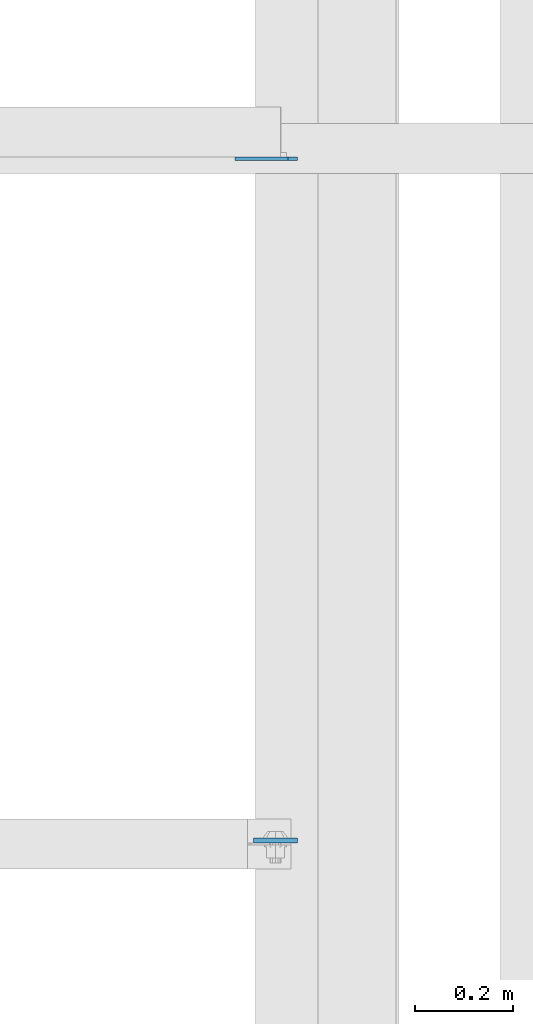
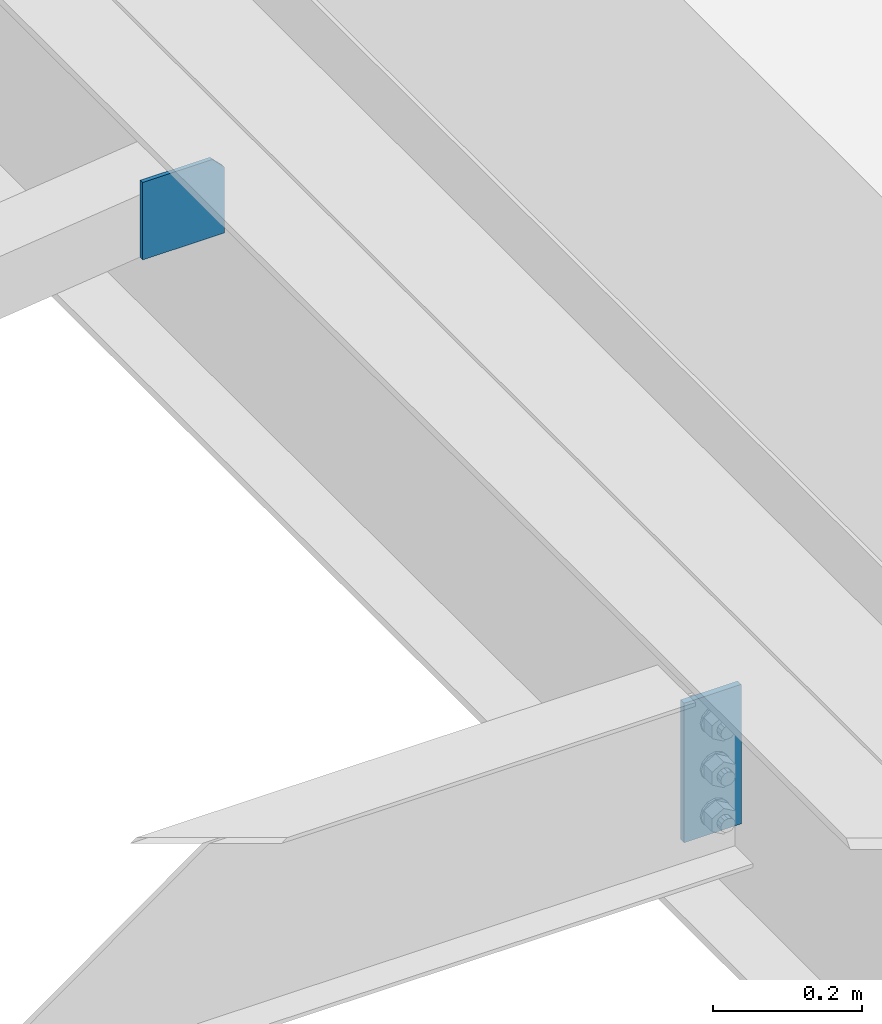
# One storey, part 3259 of 3843: 2 plates, 1 element without a shape of its own.
"""IFC2X3 building model written with IfcOpenShell, lengths in millimetres."""

import ifcopenshell
import ifcopenshell.guid

model = None  # the IFC model being written
_history = None  # IfcOwnerHistory: only IFC2X3 demands one
_inside = {}  # id of a spatial element -> (the spatial element, [elements in it])
_under = {}  # id of a project, library or spatial element -> (it, [spatial elements below it])
_declared = {}  # id of a project -> (the project, [libraries it declares])
_typed = {}  # id of a type object -> (the type object, [elements of that type])
_made_of = {}  # id of a material, layer set ... -> (it, [elements and type objects made of it])


def new_model(schema):
    """Start an empty IFC model of exactly this schema.

    Asked for "IFC4X3", IfcOpenShell would pick the latest addendum, in which some entities
    have other attributes; the version numbers below select the first issue.
    IFC2X3 requires an IfcOwnerHistory on every rooted entity: one is made here for all.
    """
    global model, _history
    if schema == "IFC4X3":
        model = ifcopenshell.file(schema_version=(4, 3, 0, 0))
    else:
        model = ifcopenshell.file(schema=schema)
    _inside.clear()
    _under.clear()
    _declared.clear()
    _typed.clear()
    _made_of.clear()
    _history = None
    if model.schema == "IFC2X3":
        org = make("IfcOrganization", Name="unknown")
        user = make(
            "IfcPersonAndOrganization",
            ThePerson=make("IfcPerson", FamilyName="unknown"),
            TheOrganization=org,
        )
        app = make(
            "IfcApplication",
            ApplicationDeveloper=org,
            Version="unknown",
            ApplicationFullName="unknown",
            ApplicationIdentifier="unknown",
        )
        _history = make(
            "IfcOwnerHistory",
            OwningUser=user,
            OwningApplication=app,
            ChangeAction="ADDED",
            CreationDate=0,
        )
    return model


def make(cls, **values):
    """One entity of the class cls with the attributes given. An attribute that is None is left unset."""
    return model.create_entity(
        cls, **{name: value for name, value in values.items() if value is not None}
    )


def rooted(cls, **values):
    """An entity with a GlobalId (a new one), such as an element, a storey or a relation."""
    return make(cls, GlobalId=ifcopenshell.guid.new(), OwnerHistory=_history, **values)


def si_unit(unit_type, name, prefix=None):
    """IfcSIUnit, for example si_unit("LENGTHUNIT", "METRE", prefix="MILLI")."""
    return make("IfcSIUnit", UnitType=unit_type, Prefix=prefix, Name=name)


def assignment(units):
    """IfcUnitAssignment: the units of a project."""
    return None if units is None else make("IfcUnitAssignment", Units=units)


def point(xyz):
    """IfcCartesianPoint."""
    return None if xyz is None else make("IfcCartesianPoint", Coordinates=xyz)


def direction(xyz):
    """IfcDirection."""
    return None if xyz is None else make("IfcDirection", DirectionRatios=xyz)


def frame(location, z_axis=None, x_axis=None):
    """IfcAxis2Placement3D, a coordinate frame: its origin and axes. An axis left out is left unset."""
    return make(
        "IfcAxis2Placement3D",
        Location=point(location),
        Axis=direction(z_axis),
        RefDirection=direction(x_axis),
    )


def origin_with_axes():
    """The frame at (0, 0, 0) with the z axis (0, 0, 1) and the x axis (1, 0, 0) written out."""
    return frame((0.0, 0.0, 0.0), z_axis=(0.0, 0.0, 1.0), x_axis=(1.0, 0.0, 0.0))


def place(relative_to, where):
    """IfcLocalPlacement: puts the frame where relative to a parent placement (None: the world)."""
    return make(
        "IfcLocalPlacement", PlacementRelTo=relative_to, RelativePlacement=where
    )


def context(
    kind, dimensions, precision=None, world=None, true_north=None, identifier=None
):
    """IfcGeometricRepresentationContext, for example the 3D "Model" context."""
    return make(
        "IfcGeometricRepresentationContext",
        ContextIdentifier=identifier,
        ContextType=kind,
        CoordinateSpaceDimension=dimensions,
        Precision=precision,
        WorldCoordinateSystem=world,
        TrueNorth=true_north,
    )


def subcontext(parent, identifier, kind, view, scale=None):
    """IfcGeometricRepresentationSubContext, for example "Body" below "Model"."""
    return make(
        "IfcGeometricRepresentationSubContext",
        ContextIdentifier=identifier,
        ContextType=kind,
        ParentContext=parent,
        TargetScale=scale,
        TargetView=view,
    )


def project(units=None, contexts=None):
    """IfcProject with its units and contexts."""
    return rooted(
        "IfcProject",
        Name="project",
        RepresentationContexts=contexts,
        UnitsInContext=assignment(units),
    )


def spatial(cls, under=None, at=None, **own):
    """A site, building, storey or space (cls), placed at a placement, below another one or the project."""
    s = rooted(cls, ObjectPlacement=at, **own)
    if under is not None:
        _under.setdefault(under.id(), (under, []))[1].append(s)
    return s


def faces_of(points, faces, orient=None, outer=None):
    """IfcFace entities. A face is a list of loops; a loop is a list of indices into points, from 0.

    orient and outer hold one flag for each loop. By default every Orientation is true, the
    first loop of a face is its IfcFaceOuterBound and the others are IfcFaceBound.
    """
    made = []
    for i, loops in enumerate(faces):
        bounds = []
        for j, loop in enumerate(loops):
            is_outer = j == 0 if outer is None else outer[i][j]
            bounds.append(
                make(
                    "IfcFaceOuterBound" if is_outer else "IfcFaceBound",
                    Bound=make("IfcPolyLoop", Polygon=[points[k] for k in loop]),
                    Orientation=True if orient is None else orient[i][j],
                )
            )
        made.append(make("IfcFace", Bounds=bounds))
    return made


def faceted_brep(points, faces, orient=None, outer=None, voids=None):
    """IfcFacetedBrep: a solid bounded by flat faces; with voids (closed shells), ...WithVoids."""
    shared = [point(p) for p in points]
    hull = make("IfcClosedShell", CfsFaces=faces_of(shared, faces, orient, outer))
    if voids is None:
        return make("IfcFacetedBrep", Outer=hull)
    return make(
        "IfcFacetedBrepWithVoids",
        Outer=hull,
        Voids=[
            make(cls, CfsFaces=faces_of(shared, fs, o, b)) for cls, fs, o, b in voids
        ],
    )


def shape(context_of_items, identifier, shape_type, items):
    """IfcShapeRepresentation: the items that make up one representation, for example the "Body"."""
    return make(
        "IfcShapeRepresentation",
        ContextOfItems=context_of_items,
        RepresentationIdentifier=identifier,
        RepresentationType=shape_type,
        Items=items,
    )


def material(Name=None, Category=None):
    """IfcMaterial."""
    return make("IfcMaterial", Name=Name, Category=Category)


def made_of(thing, what):
    """Note that an element or type object is made of a material, layer set ...; save() writes the relation."""
    if what is not None:
        _made_of.setdefault(what.id(), (what, []))[1].append(thing)
    return thing


def type_object(cls, material=None, **own):
    """A type object (cls), such as IfcWallType, which elements share."""
    return made_of(rooted(cls, **own), material)


def element(
    cls,
    number,
    at=None,
    inside=None,
    cuts=None,
    type_object=None,
    material=None,
    context=None,
    identifier="Body",
    shape_type=None,
    held_by="IfcProductDefinitionShape",
    body=None,
    shapes=None,
    **own,
):
    """One element of the class cls, such as IfcWall. Its Tag is "e" and its number.

    at: its placement. inside: the storey or other place that contains it. cuts: it is an
    opening in that element (IfcRelVoidsElement). A single representation is given by context,
    identifier, shape_type and body (its items); several are given by shapes. held_by: the class
    of the entity that holds the representations. save() writes the other relations.
    """
    e = rooted(cls, Tag="e%d" % number, ObjectPlacement=at, **own)
    if body is not None:
        shapes = [shape(context, identifier, shape_type, body)]
    if shapes is not None:
        e.Representation = make(held_by, Representations=shapes)
    if inside is not None:
        _inside.setdefault(inside.id(), (inside, []))[1].append(e)
    if cuts is not None:
        rooted(
            "IfcRelVoidsElement", RelatingBuildingElement=cuts, RelatedOpeningElement=e
        )
    if type_object is not None:
        _typed.setdefault(type_object.id(), (type_object, []))[1].append(e)
    return made_of(e, material)


def aggregate(whole, parts):
    """IfcRelAggregates: a whole, such as a stair, and the parts it consists of."""
    return rooted("IfcRelAggregates", RelatingObject=whole, RelatedObjects=parts)


def save(model, path):
    """Write the relations noted so far, then the file.

    IfcRelAggregates (storeys below a building ...), IfcRelContainedInSpatialStructure (elements
    in a storey), IfcRelDefinesByType, IfcRelAssociatesMaterial and IfcRelDeclares: one each for
    every whole, place, type object, material and project.
    """
    for whole, parts in _under.values():
        aggregate(whole, parts)
    for where, things in _inside.values():
        rooted(
            "IfcRelContainedInSpatialStructure",
            RelatedElements=things,
            RelatingStructure=where,
        )
    for kind, things in _typed.values():
        rooted("IfcRelDefinesByType", RelatedObjects=things, RelatingType=kind)
    for what, things in _made_of.values():
        rooted("IfcRelAssociatesMaterial", RelatedObjects=things, RelatingMaterial=what)
    for by, libraries in _declared.values():
        rooted("IfcRelDeclares", RelatingContext=by, RelatedDefinitions=libraries)
    model.write(path)


model = new_model("IFC2X3")

# Units and contexts
model_context = context("Model", 3, precision=1e-05, world=origin_with_axes())
body_context = subcontext(model_context, "Body", "Model", "MODEL_VIEW")
ifc_project = project(units=[si_unit("LENGTHUNIT", "METRE", prefix="MILLI"), si_unit("AREAUNIT", "SQUARE_METRE"), si_unit("VOLUMEUNIT", "CUBIC_METRE"), si_unit("MASSUNIT", "GRAM", prefix="KILO"), si_unit("TIMEUNIT", "SECOND"), si_unit("PLANEANGLEUNIT", "RADIAN"), si_unit("SOLIDANGLEUNIT", "STERADIAN"), si_unit("THERMODYNAMICTEMPERATUREUNIT", "DEGREE_CELSIUS"), si_unit("LUMINOUSINTENSITYUNIT", "LUMEN")], contexts=[model_context])

# Site, building, storey
site_placement = place(None, origin_with_axes())
site = spatial("IfcSite", under=ifc_project, at=site_placement, CompositionType="ELEMENT")
building_placement = place(site_placement, origin_with_axes())
building = spatial("IfcBuilding", under=site, at=building_placement, Name="Undefined", CompositionType="ELEMENT")
storey_placement = place(building_placement, origin_with_axes())
storey = spatial("IfcBuildingStorey", under=building, at=storey_placement, Name="Undefined", CompositionType="ELEMENT", Elevation=0.0)

# Assembly, plates
assembly_placement = place(storey_placement, origin_with_axes())
assembly = element("IfcElementAssembly", 1, at=assembly_placement, inside=storey, Name="BEAM", AssemblyPlace="NOTDEFINED", PredefinedType="RIGID_FRAME")
ifc_material = material(Name="STEEL/A572-50")
plate_type_1 = type_object("IfcPlateType", PredefinedType="NOTDEFINED")
plate_1_placement = place(assembly_placement, frame((38816.75625, 47780.178126, 33997.9), z_axis=(-1.0, 0.0, 0.0), x_axis=(0.0, 0.0, -1.0)))
plate_1 = element("IfcPlate", 2, at=plate_1_placement, type_object=plate_type_1, material=ifc_material, Name="PLATE", context=body_context, shape_type="Brep", body=[
    faceted_brep([(0.0, -4.76249999999709, 0.0), (0.0, -4.76249999999709, 88.9000015258789), (0.0, 4.76249999999709, 88.9000015258789), (0.0, 4.76249999999709, 0.0), (228.600006102781, -4.7625000004191, 88.9000015257589), (228.600006102781, 4.76249999954598, 88.9000015257443), (228.600006103079, -4.7625000004482, 7.27595761418343e-12), (228.600006103079, 4.76249999954598, -7.27595761418343e-12)], [[[0, 1, 2, 3]], [[1, 4, 5, 2]], [[4, 6, 7, 5]], [[6, 0, 3, 7]], [[5, 7, 3, 2]], [[6, 4, 1, 0]]]),
])
plate_type_2 = type_object("IfcPlateType", PredefinedType="NOTDEFINED")
plate_2_placement = place(assembly_placement, frame((38816.75625, 49165.867188, 33896.3), z_axis=(0.0, 0.0, 1.0), x_axis=(-1.0, 0.0, 0.0)))
plate_2 = element("IfcPlate", 3, at=plate_2_placement, type_object=plate_type_2, material=ifc_material, Name="PLATE", context=body_context, shape_type="Brep", body=[
    faceted_brep([(0.0, -3.17499999999927, 0.0), (0.0, -3.17500000000291, 107.950000000004), (0.0, 3.17500000000291, 107.950000000004), (0.0, 3.17499999999927, 0.0), (19.0500000000029, -3.17500000000291, 127.0), (19.0500000000029, 3.17500000000291, 127.0), (127.0, -3.17500000000291, 127.0), (127.0, 3.17500000000291, 127.0), (127.0, -3.17500000000291, 0.0), (127.0, 3.17500000000291, 0.0)], [[[0, 1, 2, 3]], [[1, 4, 5, 2]], [[4, 6, 7, 5]], [[6, 8, 9, 7]], [[8, 0, 3, 9]], [[5, 7, 9, 3, 2]], [[8, 6, 4, 1, 0]]]),
])
aggregate(assembly, [plate_2, plate_1])

save(model, "model.ifc")
